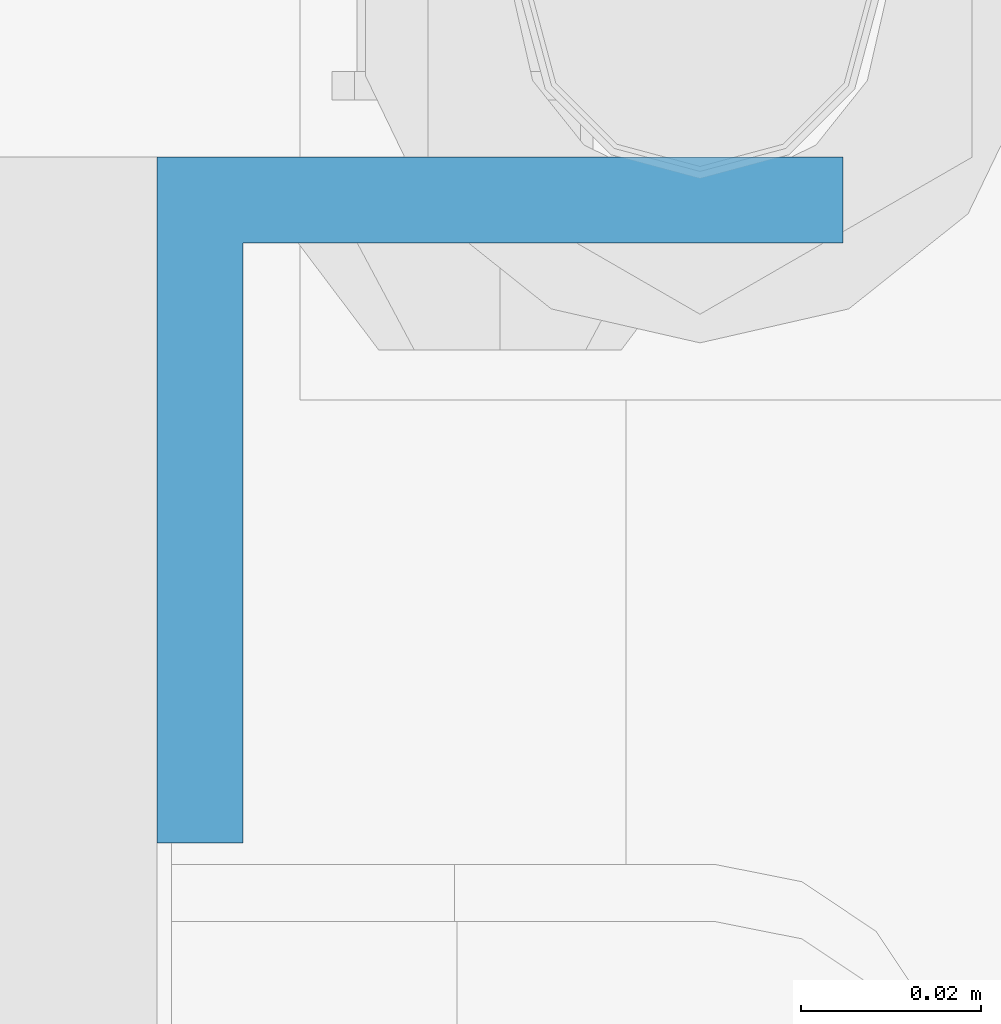
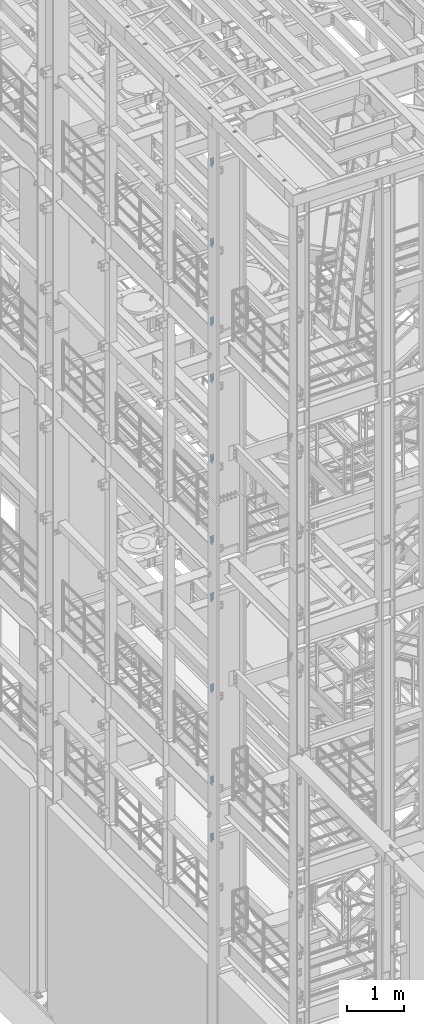
# One storey, part 815 of 1876: 10 columns, 2 elements without a shape of their own.
"""IFC2X3 building model written with IfcOpenShell, lengths in millimetres."""

from ifc_helpers import new_model, si_unit, frame, origin_with_axes, place, context, subcontext, project, spatial, faceted_brep, material, type_object, element, aggregate, save


model = new_model("IFC2X3")

# Units and contexts
model_context = context("Model", 3, precision=1e-05, world=origin_with_axes())
body_context = subcontext(model_context, "Body", "Model", "MODEL_VIEW")
ifc_project = project(units=[si_unit("LENGTHUNIT", "METRE", prefix="MILLI"), si_unit("AREAUNIT", "SQUARE_METRE"), si_unit("VOLUMEUNIT", "CUBIC_METRE"), si_unit("MASSUNIT", "GRAM", prefix="KILO"), si_unit("TIMEUNIT", "SECOND"), si_unit("PLANEANGLEUNIT", "RADIAN"), si_unit("SOLIDANGLEUNIT", "STERADIAN"), si_unit("THERMODYNAMICTEMPERATUREUNIT", "DEGREE_CELSIUS"), si_unit("LUMINOUSINTENSITYUNIT", "LUMEN")], contexts=[model_context])

# Site, building, storey
site_placement = place(None, origin_with_axes())
site = spatial("IfcSite", under=ifc_project, at=site_placement, CompositionType="ELEMENT")
building_placement = place(site_placement, origin_with_axes())
building = spatial("IfcBuilding", under=site, at=building_placement, Name="Undefined", CompositionType="ELEMENT")
storey_placement = place(building_placement, origin_with_axes())
storey = spatial("IfcBuildingStorey", under=building, at=storey_placement, Name="Undefined", CompositionType="ELEMENT", Elevation=0.0)

# Assembly, columns
assembly_1_placement = place(storey_placement, origin_with_axes())
assembly_1 = element("IfcElementAssembly", 1, at=assembly_1_placement, inside=storey, Name="COLUMN", AssemblyPlace="NOTDEFINED", PredefinedType="RIGID_FRAME")
ifc_material = material(Name="STEEL/A36")
column_type = type_object("IfcColumnType", Name="L3X3X3/8", PredefinedType="NOTDEFINED")
column_1_placement = place(assembly_1_placement, frame((-212.725, -4449.7625, 21602.7), z_axis=(0.0, -1.0, 0.0), x_axis=(0.0, 0.0, 1.0)))
column_1 = element("IfcColumn", 2, at=column_1_placement, type_object=column_type, material=ifc_material, Name="ANGLE", ObjectType="L3X3X3/8", context=body_context, shape_type="Brep", body=[
    faceted_brep([(0.0, 38.1000000000004, -38.1), (0.0, 38.1000000000004, 38.1), (152.4, 38.1000000000004, 38.1), (152.4, 38.1000000000004, -38.1), (0.0, 28.5749999999998, 38.1), (152.4, 28.5749999999998, 38.1), (0.0, 28.5749999999998, -28.575), (152.4, 28.5749999999998, -28.575), (0.0, -38.1000000000004, -28.575), (152.4, -38.1000000000004, -28.575), (0.0, -38.1000000000004, -38.1), (152.4, -38.1000000000004, -38.1)], [[[0, 1, 2, 3]], [[1, 4, 5, 2]], [[4, 6, 7, 5]], [[6, 8, 9, 7]], [[8, 10, 11, 9]], [[10, 0, 3, 11]], [[5, 7, 9, 11, 3, 2]], [[10, 8, 6, 4, 1, 0]]]),
])
column_2_placement = place(assembly_1_placement, frame((-212.725, -4449.7625, 19881.85), z_axis=(0.0, -1.0, 0.0), x_axis=(0.0, 0.0, 1.0)))
column_2 = element("IfcColumn", 3, at=column_2_placement, type_object=column_type, material=ifc_material, Name="ANGLE", ObjectType="L3X3X3/8", context=body_context, shape_type="Brep", body=[
    faceted_brep([(0.0, 38.1000000000004, -38.1), (0.0, 38.1000000000004, 38.1), (152.4, 38.1000000000004, 38.1), (152.4, 38.1000000000004, -38.1), (0.0, 28.5749999999998, 38.1), (152.4, 28.5749999999998, 38.1), (0.0, 28.5749999999998, -28.575), (152.4, 28.5749999999998, -28.575), (0.0, -38.1000000000004, -28.575), (152.4, -38.1000000000004, -28.575), (0.0, -38.1000000000004, -38.1), (152.4, -38.1000000000004, -38.1)], [[[0, 1, 2, 3]], [[1, 4, 5, 2]], [[4, 6, 7, 5]], [[6, 8, 9, 7]], [[8, 10, 11, 9]], [[10, 0, 3, 11]], [[5, 7, 9, 11, 3, 2]], [[10, 8, 6, 4, 1, 0]]]),
])
column_3_placement = place(assembly_1_placement, frame((-212.725, -4449.7625, 18199.1), z_axis=(0.0, -1.0, 0.0), x_axis=(0.0, 0.0, 1.0)))
column_3 = element("IfcColumn", 4, at=column_3_placement, type_object=column_type, material=ifc_material, Name="ANGLE", ObjectType="L3X3X3/8", context=body_context, shape_type="Brep", body=[
    faceted_brep([(0.0, 38.1000000000004, -38.1), (0.0, 38.1000000000004, 38.1), (152.4, 38.1000000000004, 38.1), (152.4, 38.1000000000004, -38.1), (0.0, 28.5749999999998, 38.1), (152.4, 28.5749999999998, 38.1), (0.0, 28.5749999999998, -28.575), (152.4, 28.5749999999998, -28.575), (0.0, -38.1000000000004, -28.575), (152.4, -38.1000000000004, -28.575), (0.0, -38.1000000000004, -38.1), (152.4, -38.1000000000004, -38.1)], [[[0, 1, 2, 3]], [[1, 4, 5, 2]], [[4, 6, 7, 5]], [[6, 8, 9, 7]], [[8, 10, 11, 9]], [[10, 0, 3, 11]], [[5, 7, 9, 11, 3, 2]], [[10, 8, 6, 4, 1, 0]]]),
])
column_4_placement = place(assembly_1_placement, frame((-212.725, -4449.7625, 16979.9), z_axis=(0.0, -1.0, 0.0), x_axis=(0.0, 0.0, 1.0)))
column_4 = element("IfcColumn", 5, at=column_4_placement, type_object=column_type, material=ifc_material, Name="ANGLE", ObjectType="L3X3X3/8", context=body_context, shape_type="Brep", body=[
    faceted_brep([(0.0, 38.1000000000004, -38.1), (0.0, 38.1000000000004, 38.1), (152.4, 38.1000000000004, 38.1), (152.4, 38.1000000000004, -38.1), (0.0, 28.5749999999998, 38.1), (152.4, 28.5749999999998, 38.1), (0.0, 28.5749999999998, -28.575), (152.4, 28.5749999999998, -28.575), (0.0, -38.1000000000004, -28.575), (152.4, -38.1000000000004, -28.575), (0.0, -38.1000000000004, -38.1), (152.4, -38.1000000000004, -38.1)], [[[0, 1, 2, 3]], [[1, 4, 5, 2]], [[4, 6, 7, 5]], [[6, 8, 9, 7]], [[8, 10, 11, 9]], [[10, 0, 3, 11]], [[5, 7, 9, 11, 3, 2]], [[10, 8, 6, 4, 1, 0]]]),
])
column_5_placement = place(assembly_1_placement, frame((-212.725, -4449.7625, 15259.05), z_axis=(0.0, -1.0, 0.0), x_axis=(0.0, 0.0, 1.0)))
column_5 = element("IfcColumn", 6, at=column_5_placement, type_object=column_type, material=ifc_material, Name="ANGLE", ObjectType="L3X3X3/8", context=body_context, shape_type="Brep", body=[
    faceted_brep([(0.0, 38.1000000000004, -38.1), (0.0, 38.1000000000004, 38.1), (152.4, 38.1000000000004, 38.1), (152.4, 38.1000000000004, -38.1), (0.0, 28.5749999999998, 38.1), (152.4, 28.5749999999998, 38.1), (0.0, 28.5749999999998, -28.575), (152.4, 28.5749999999998, -28.575), (0.0, -38.1000000000004, -28.575), (152.4, -38.1000000000004, -28.575), (0.0, -38.1000000000004, -38.1), (152.4, -38.1000000000004, -38.1)], [[[0, 1, 2, 3]], [[1, 4, 5, 2]], [[4, 6, 7, 5]], [[6, 8, 9, 7]], [[8, 10, 11, 9]], [[10, 0, 3, 11]], [[5, 7, 9, 11, 3, 2]], [[10, 8, 6, 4, 1, 0]]]),
])
aggregate(assembly_1, [column_1, column_2, column_3, column_4, column_5])

assembly_2_placement = place(storey_placement, origin_with_axes())
assembly_2 = element("IfcElementAssembly", 7, at=assembly_2_placement, inside=storey, Name="COLUMN", AssemblyPlace="NOTDEFINED", PredefinedType="RIGID_FRAME")
column_6_placement = place(assembly_2_placement, frame((-212.725, -4449.7625, 13512.8), z_axis=(0.0, -1.0, 0.0), x_axis=(0.0, 0.0, 1.0)))
column_6 = element("IfcColumn", 8, at=column_6_placement, type_object=column_type, material=ifc_material, Name="ANGLE", ObjectType="L3X3X3/8", context=body_context, shape_type="Brep", body=[
    faceted_brep([(0.0, 38.1000000000004, -38.1), (0.0, 38.1000000000004, 38.1), (152.4, 38.1000000000004, 38.1), (152.4, 38.1000000000004, -38.1), (0.0, 28.5749999999998, 38.1), (152.4, 28.5749999999998, 38.1), (0.0, 28.5749999999998, -28.575), (152.4, 28.5749999999998, -28.575), (0.0, -38.1000000000004, -28.575), (152.4, -38.1000000000004, -28.575), (0.0, -38.1000000000004, -38.1), (152.4, -38.1000000000004, -38.1)], [[[0, 1, 2, 3]], [[1, 4, 5, 2]], [[4, 6, 7, 5]], [[6, 8, 9, 7]], [[8, 10, 11, 9]], [[10, 0, 3, 11]], [[5, 7, 9, 11, 3, 2]], [[10, 8, 6, 4, 1, 0]]]),
])
column_7_placement = place(assembly_2_placement, frame((-212.725, -4449.7625, 12293.6), z_axis=(0.0, -1.0, 0.0), x_axis=(0.0, 0.0, 1.0)))
column_7 = element("IfcColumn", 9, at=column_7_placement, type_object=column_type, material=ifc_material, Name="ANGLE", ObjectType="L3X3X3/8", context=body_context, shape_type="Brep", body=[
    faceted_brep([(0.0, 38.1000000000004, -38.1), (0.0, 38.1000000000004, 38.1), (152.4, 38.1000000000004, 38.1), (152.4, 38.1000000000004, -38.1), (0.0, 28.5749999999998, 38.1), (152.4, 28.5749999999998, 38.1), (0.0, 28.5749999999998, -28.575), (152.4, 28.5749999999998, -28.575), (0.0, -38.1000000000004, -28.575), (152.4, -38.1000000000004, -28.575), (0.0, -38.1000000000004, -38.1), (152.4, -38.1000000000004, -38.1)], [[[0, 1, 2, 3]], [[1, 4, 5, 2]], [[4, 6, 7, 5]], [[6, 8, 9, 7]], [[8, 10, 11, 9]], [[10, 0, 3, 11]], [[5, 7, 9, 11, 3, 2]], [[10, 8, 6, 4, 1, 0]]]),
])
column_8_placement = place(assembly_2_placement, frame((-212.725, -4449.7625, 10344.15), z_axis=(0.0, -1.0, 0.0), x_axis=(0.0, 0.0, 1.0)))
column_8 = element("IfcColumn", 10, at=column_8_placement, type_object=column_type, material=ifc_material, Name="ANGLE", ObjectType="L3X3X3/8", context=body_context, shape_type="Brep", body=[
    faceted_brep([(0.0, 38.1000000000004, -38.1), (0.0, 38.1000000000004, 38.1), (152.4, 38.1000000000004, 38.1), (152.4, 38.1000000000004, -38.1), (0.0, 28.5749999999998, 38.1), (152.4, 28.5749999999998, 38.1), (0.0, 28.5749999999998, -28.575), (152.4, 28.5749999999998, -28.575), (0.0, -38.1000000000004, -28.575), (152.4, -38.1000000000004, -28.575), (0.0, -38.1000000000004, -38.1), (152.4, -38.1000000000004, -38.1)], [[[0, 1, 2, 3]], [[1, 4, 5, 2]], [[4, 6, 7, 5]], [[6, 8, 9, 7]], [[8, 10, 11, 9]], [[10, 0, 3, 11]], [[5, 7, 9, 11, 3, 2]], [[10, 8, 6, 4, 1, 0]]]),
])
column_9_placement = place(assembly_2_placement, frame((-212.725, -4449.7625, 8369.3), z_axis=(0.0, -1.0, 0.0), x_axis=(0.0, 0.0, 1.0)))
column_9 = element("IfcColumn", 11, at=column_9_placement, type_object=column_type, material=ifc_material, Name="ANGLE", ObjectType="L3X3X3/8", context=body_context, shape_type="Brep", body=[
    faceted_brep([(0.0, 38.1000000000004, -38.1), (0.0, 38.1000000000004, 38.1), (152.4, 38.1000000000004, 38.1), (152.4, 38.1000000000004, -38.1), (0.0, 28.5749999999998, 38.1), (152.4, 28.5749999999998, 38.1), (0.0, 28.5749999999998, -28.575), (152.4, 28.5749999999998, -28.575), (0.0, -38.1000000000004, -28.575), (152.4, -38.1000000000004, -28.575), (0.0, -38.1000000000004, -38.1), (152.4, -38.1000000000004, -38.1)], [[[0, 1, 2, 3]], [[1, 4, 5, 2]], [[4, 6, 7, 5]], [[6, 8, 9, 7]], [[8, 10, 11, 9]], [[10, 0, 3, 11]], [[5, 7, 9, 11, 3, 2]], [[10, 8, 6, 4, 1, 0]]]),
])
column_10_placement = place(assembly_2_placement, frame((-212.725, -4449.7625, 7150.1), z_axis=(0.0, -1.0, 0.0), x_axis=(0.0, 0.0, 1.0)))
column_10 = element("IfcColumn", 12, at=column_10_placement, type_object=column_type, material=ifc_material, Name="ANGLE", ObjectType="L3X3X3/8", context=body_context, shape_type="Brep", body=[
    faceted_brep([(0.0, 38.1000000000004, -38.1), (0.0, 38.1000000000004, 38.1), (152.4, 38.1000000000004, 38.1), (152.4, 38.1000000000004, -38.1), (0.0, 28.5749999999998, 38.1), (152.4, 28.5749999999998, 38.1), (0.0, 28.5749999999998, -28.575), (152.4, 28.5749999999998, -28.575), (0.0, -38.1000000000004, -28.575), (152.4, -38.1000000000004, -28.575), (0.0, -38.1000000000004, -38.1), (152.4, -38.1000000000004, -38.1)], [[[0, 1, 2, 3]], [[1, 4, 5, 2]], [[4, 6, 7, 5]], [[6, 8, 9, 7]], [[8, 10, 11, 9]], [[10, 0, 3, 11]], [[5, 7, 9, 11, 3, 2]], [[10, 8, 6, 4, 1, 0]]]),
])
aggregate(assembly_2, [column_6, column_7, column_8, column_9, column_10])

save(model, "model.ifc")
